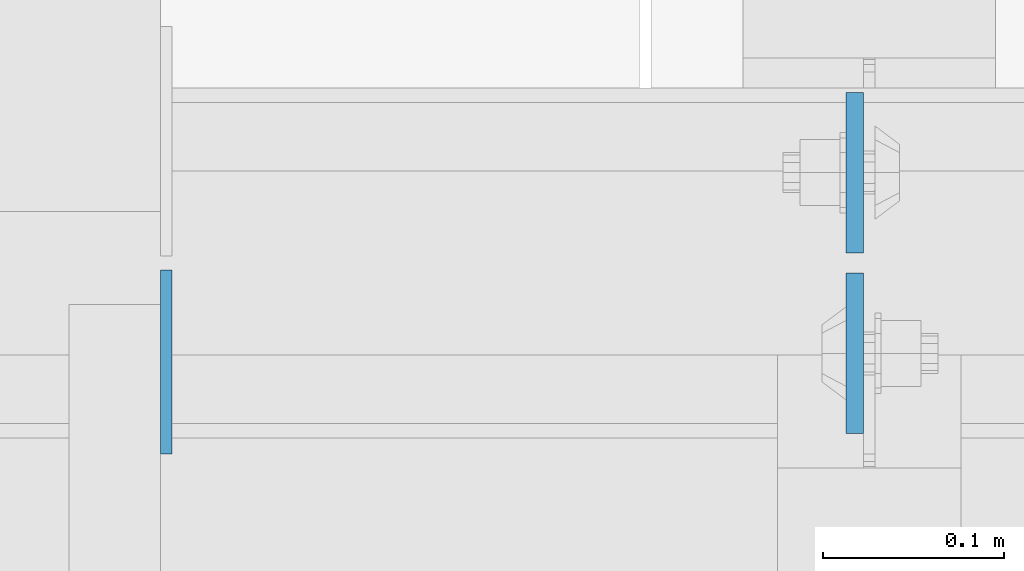
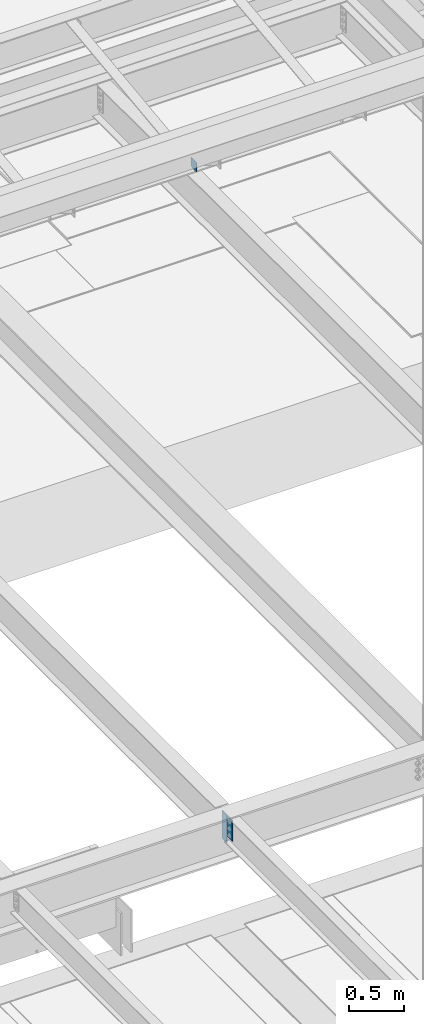
# One storey, part 3069 of 3843: 3 plates, 2 elements without a shape of their own.
"""IFC2X3 building model written with IfcOpenShell, lengths in millimetres."""

from ifc_helpers import new_model, si_unit, frame, origin_with_axes, place, context, subcontext, project, spatial, faceted_brep, material, type_object, element, aggregate, save


model = new_model("IFC2X3")

# Units and contexts
model_context = context("Model", 3, precision=1e-05, world=origin_with_axes())
body_context = subcontext(model_context, "Body", "Model", "MODEL_VIEW")
ifc_project = project(units=[si_unit("LENGTHUNIT", "METRE", prefix="MILLI"), si_unit("AREAUNIT", "SQUARE_METRE"), si_unit("VOLUMEUNIT", "CUBIC_METRE"), si_unit("MASSUNIT", "GRAM", prefix="KILO"), si_unit("TIMEUNIT", "SECOND"), si_unit("PLANEANGLEUNIT", "RADIAN"), si_unit("SOLIDANGLEUNIT", "STERADIAN"), si_unit("THERMODYNAMICTEMPERATUREUNIT", "DEGREE_CELSIUS"), si_unit("LUMINOUSINTENSITYUNIT", "LUMEN")], contexts=[model_context])

# Site, building, storey
site_placement = place(None, origin_with_axes())
site = spatial("IfcSite", under=ifc_project, at=site_placement, CompositionType="ELEMENT")
building_placement = place(site_placement, origin_with_axes())
building = spatial("IfcBuilding", under=site, at=building_placement, Name="Undefined", CompositionType="ELEMENT")
storey_placement = place(building_placement, origin_with_axes())
storey = spatial("IfcBuildingStorey", under=building, at=storey_placement, Name="Undefined", CompositionType="ELEMENT", Elevation=0.0)

# Assembly, plates
assembly_1_placement = place(storey_placement, origin_with_axes())
assembly_1 = element("IfcElementAssembly", 1, at=assembly_1_placement, inside=storey, Name="BEAM", AssemblyPlace="NOTDEFINED", PredefinedType="RIGID_FRAME")
ifc_material = material(Name="STEEL/A572-50")
plate_type_1 = type_object("IfcPlateType", PredefinedType="NOTDEFINED")
plate_1_placement = place(assembly_1_placement, frame((60393.2625, 15004.25625, 34772.6), z_axis=(0.0, 1.0, 0.0), x_axis=(0.0, 0.0, -1.0)))
plate_1 = element("IfcPlate", 2, at=plate_1_placement, type_object=plate_type_1, material=ifc_material, Name="PLATE", context=body_context, shape_type="Brep", body=[
    faceted_brep([(0.0, -4.76249999999709, 0.0), (0.0, -4.76249999999709, 88.9000015258789), (0.0, 4.76249999999709, 88.9000015258789), (0.0, 4.76249999999709, 0.0), (304.800000000003, -4.76249999999709, 88.8999999999942), (304.800000000003, 4.76249999999709, 88.8999999999942), (304.800000000003, -4.76249999999709, 0.0), (304.800000000003, 4.76249999999709, 0.0)], [[[0, 1, 2, 3]], [[1, 4, 5, 2]], [[4, 6, 7, 5]], [[6, 0, 3, 7]], [[5, 7, 3, 2]], [[6, 4, 1, 0]]]),
])
plate_2_placement = place(assembly_1_placement, frame((60393.2625, 14993.14375, 34772.6), z_axis=(0.0, -1.0, 0.0), x_axis=(0.0, 0.0, -1.0)))
plate_2 = element("IfcPlate", 3, at=plate_2_placement, type_object=plate_type_1, material=ifc_material, Name="PLATE", context=body_context, shape_type="Brep", body=[
    faceted_brep([(0.0, -4.76249999999709, 0.0), (0.0, -4.76249999999709, 88.9000015258789), (0.0, 4.76249999999709, 88.9000015258789), (0.0, 4.76249999999709, 0.0), (228.600006102781, -4.7625000004191, 88.9000015257589), (228.600006102781, 4.76249999954598, 88.9000015257443), (228.600006103079, -4.7625000004482, 7.27595761418343e-12), (228.600006103079, 4.76249999954598, -7.27595761418343e-12)], [[[0, 1, 2, 3]], [[1, 4, 5, 2]], [[4, 6, 7, 5]], [[6, 0, 3, 7]], [[5, 7, 3, 2]], [[6, 4, 1, 0]]]),
])
aggregate(assembly_1, [plate_1, plate_2])

# Assembly, plate
assembly_2_placement = place(storey_placement, origin_with_axes())
assembly_2 = element("IfcElementAssembly", 4, at=assembly_2_placement, inside=storey, Name="BEAM", AssemblyPlace="NOTDEFINED", PredefinedType="RIGID_FRAME")
plate_type_2 = type_object("IfcPlateType", PredefinedType="NOTDEFINED")
plate_3_placement = place(assembly_2_placement, frame((60012.2625, 14893.13125, 42075.1), z_axis=(0.0, 0.0, 1.0), x_axis=(0.0, 1.0, 0.0)))
plate_3 = element("IfcPlate", 5, at=plate_3_placement, type_object=plate_type_2, material=ifc_material, Name="PLATE", context=body_context, shape_type="Brep", body=[
    faceted_brep([(0.0, -3.17499999999927, 0.0), (0.0, -3.17499999999927, 101.600000000006), (0.0, 3.17499999999927, 101.600000000006), (0.0, 3.17499999999927, 0.0), (101.6, -3.17500000000291, 101.599999999999), (101.6, 3.17500000000291, 101.599999999999), (101.6, -3.17500000000291, 19.0499992370605), (101.6, 3.17500000000291, 19.0499992370605), (82.5500007629398, -3.17500000000291, 0.0), (82.5500007629398, 3.17500000000291, 0.0)], [[[0, 1, 2, 3]], [[1, 4, 5, 2]], [[4, 6, 7, 5]], [[6, 8, 9, 7]], [[8, 0, 3, 9]], [[5, 7, 9, 3, 2]], [[8, 6, 4, 1, 0]]]),
])
aggregate(assembly_2, [plate_3])

save(model, "model.ifc")
